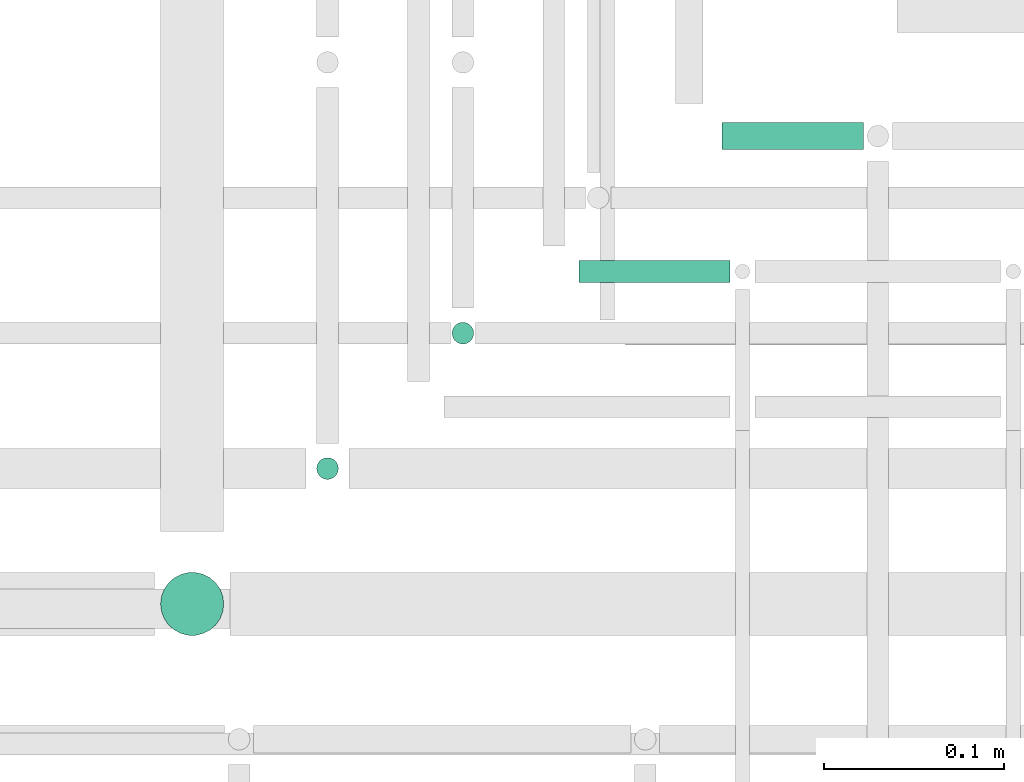
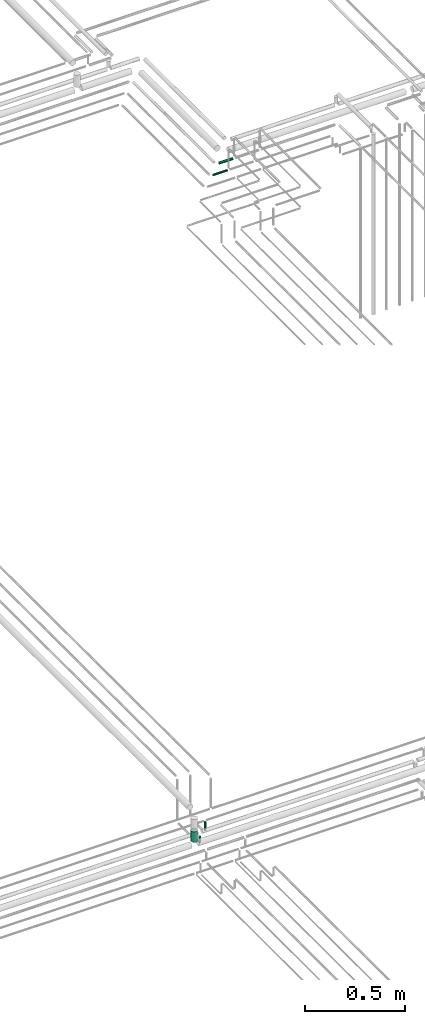
# One storey, part 296 of 331: 5 flow segments.
"""IFC2X3 building model written with IfcOpenShell, lengths in millimetres."""

from ifc_helpers import new_model, entity, si_unit, converted_unit, derived_unit, direction, frame, frame_2d, origin, origin_2d_with_axis, place, context, subcontext, project, spatial, circle, extrude, type_object, element, save


model = new_model("IFC2X3")

# Units and contexts
model_context = context("Model", 3, precision=0.01, world=origin(), true_north=direction((6.12303176911189e-17, 1.0)))
body_context = subcontext(model_context, "Body", "Model", "MODEL_VIEW")
ifc_project = project(units=[si_unit("LENGTHUNIT", "METRE", prefix="MILLI"), si_unit("AREAUNIT", "SQUARE_METRE"), si_unit("VOLUMEUNIT", "CUBIC_METRE"), converted_unit("PLANEANGLEUNIT", "DEGREE", entity("IfcRatioMeasure", 0.0174532925199433), si_unit("PLANEANGLEUNIT", "RADIAN"), dimensions=[0, 0, 0, 0, 0, 0, 0]), si_unit("MASSUNIT", "GRAM", prefix="KILO"), derived_unit("MASSDENSITYUNIT", [(si_unit("MASSUNIT", "GRAM", prefix="KILO"), 1), (si_unit("LENGTHUNIT", "METRE"), -3)]), derived_unit("MOMENTOFINERTIAUNIT", [(si_unit("LENGTHUNIT", "METRE"), 4)]), si_unit("TIMEUNIT", "SECOND"), si_unit("FREQUENCYUNIT", "HERTZ"), si_unit("THERMODYNAMICTEMPERATUREUNIT", "DEGREE_CELSIUS"), derived_unit("THERMALTRANSMITTANCEUNIT", [(si_unit("MASSUNIT", "GRAM", prefix="KILO"), 1), (si_unit("THERMODYNAMICTEMPERATUREUNIT", "KELVIN"), -1), (si_unit("TIMEUNIT", "SECOND"), -3)]), derived_unit("VOLUMETRICFLOWRATEUNIT", [(si_unit("LENGTHUNIT", "METRE"), 3), (si_unit("TIMEUNIT", "SECOND"), -1)]), derived_unit("MASSFLOWRATEUNIT", [(si_unit("MASSUNIT", "GRAM", prefix="KILO"), 1), (si_unit("TIMEUNIT", "SECOND"), -1)]), derived_unit("ROTATIONALFREQUENCYUNIT", [(si_unit("TIMEUNIT", "SECOND"), -1)]), si_unit("ELECTRICCURRENTUNIT", "AMPERE"), si_unit("ELECTRICVOLTAGEUNIT", "VOLT"), si_unit("POWERUNIT", "WATT"), si_unit("FORCEUNIT", "NEWTON", prefix="KILO"), si_unit("ILLUMINANCEUNIT", "LUX"), si_unit("LUMINOUSFLUXUNIT", "LUMEN"), si_unit("LUMINOUSINTENSITYUNIT", "CANDELA"), derived_unit("USERDEFINED", [(si_unit("MASSUNIT", "GRAM", prefix="KILO"), -1), (si_unit("LENGTHUNIT", "METRE"), -2), (si_unit("TIMEUNIT", "SECOND"), 3), (si_unit("LUMINOUSFLUXUNIT", "LUMEN"), 1)]), derived_unit("LINEARVELOCITYUNIT", [(si_unit("LENGTHUNIT", "METRE"), 1), (si_unit("TIMEUNIT", "SECOND"), -1)]), si_unit("PRESSUREUNIT", "PASCAL"), derived_unit("USERDEFINED", [(si_unit("LENGTHUNIT", "METRE"), -2), (si_unit("MASSUNIT", "GRAM", prefix="KILO"), 1), (si_unit("TIMEUNIT", "SECOND"), -2)]), derived_unit("LINEARFORCEUNIT", [(si_unit("MASSUNIT", "GRAM", prefix="KILO"), 1), (si_unit("LENGTHUNIT", "METRE"), 1), (si_unit("TIMEUNIT", "SECOND"), -2), (si_unit("LENGTHUNIT", "METRE"), -1)]), derived_unit("PLANARFORCEUNIT", [(si_unit("MASSUNIT", "GRAM", prefix="KILO"), 1), (si_unit("LENGTHUNIT", "METRE"), 1), (si_unit("TIMEUNIT", "SECOND"), -2), (si_unit("LENGTHUNIT", "METRE"), -2)])], contexts=[model_context])

# Site, building, storey
site_placement = place(None, frame((0.0, -0.00077364408347762, 0.0)))
site = spatial("IfcSite", under=ifc_project, at=site_placement, CompositionType="ELEMENT")
building_placement = place(site_placement, origin())
building = spatial("IfcBuilding", under=site, at=building_placement, CompositionType="ELEMENT")
storey_placement = place(building_placement, origin())
storey = spatial("IfcBuildingStorey", under=building, at=storey_placement, CompositionType="ELEMENT", Elevation=0.0)

# Flow segments
pipe_segment_type = type_object("IfcPipeSegmentType", PredefinedType="NOTDEFINED")
flow_segment_1_placement = place(storey_placement, frame((62137.5132590569, 8593.02529159146, 14489.0)))
element("IfcFlowSegment", 1, at=flow_segment_1_placement, inside=storey, type_object=pipe_segment_type, context=body_context, shape_type="SweptSolid", body=[
    extrude(circle(Radius=6.0, at=frame_2d((0.0, 1.08286712929839e-12), x_axis=(1.0, 0.0))), frame((7.59527223591454, 7.59527223591454, 0.0)), (0.0, 0.0, 1.0), 54.0000000000051),
])
flow_segment_2_placement = place(storey_placement, frame((62062.5132590569, 8518.02529159144, 14489.0)))
element("IfcFlowSegment", 2, at=flow_segment_2_placement, inside=storey, type_object=pipe_segment_type, context=body_context, shape_type="SweptSolid", body=[
    extrude(circle(Radius=6.0, at=frame_2d((0.0, 1.08286712929839e-12), x_axis=(1.0, 0.0))), frame((7.59527223591454, 7.59527223591454, 0.0)), (0.0, 0.0, 1.0), 37.0000000000046),
])
flow_segment_3_placement = place(storey_placement, frame((61976.013259057, 8431.52529159143, 14571.0)))
element("IfcFlowSegment", 3, at=flow_segment_3_placement, inside=storey, type_object=pipe_segment_type, context=body_context, shape_type="SweptSolid", body=[
    extrude(circle(Radius=17.5, at=origin_2d_with_axis()), frame((19.0952722359119, 19.0952722359163, 0.0), z_axis=(0.0, 0.0, 1.0), x_axis=(-1.0, 0.0, 0.0)), (0.0, 0.0, 1.0), 65.0000000000805),
])
flow_segment_4_placement = place(storey_placement, frame((62209.5243524318, 8627.21546224651, 18442.4047277642)))
element("IfcFlowSegment", 4, at=flow_segment_4_placement, inside=storey, type_object=pipe_segment_type, context=body_context, shape_type="SweptSolid", body=[
    extrude(circle(Radius=6.0, at=frame_2d((1.40772726808791e-11, -2.16573425859679e-12), x_axis=(1.0, 0.0))), frame((0.0, 7.59527223592861, 7.59527223591887), z_axis=(1.0, 0.0, 0.0), x_axis=(0.0, 1.0, 0.0)), (0.0, 0.0, 1.0), 83.4844510712905),
])
flow_segment_5_placement = place(storey_placement, frame((62288.5243524318, 8700.7154622465, 18440.9047277641)))
element("IfcFlowSegment", 5, at=flow_segment_5_placement, inside=storey, type_object=pipe_segment_type, context=body_context, shape_type="SweptSolid", body=[
    extrude(circle(Radius=7.5, at=frame_2d((9.74580416368554e-12, -2.16573425859679e-12), x_axis=(1.0, 0.0))), frame((0.0, 9.09527223592611, 9.09527223591853), z_axis=(1.0, 0.0, 0.0), x_axis=(0.0, 1.0, 0.0)), (0.0, 0.0, 1.0), 78.4844510712916),
])

save(model, "model.ifc")
